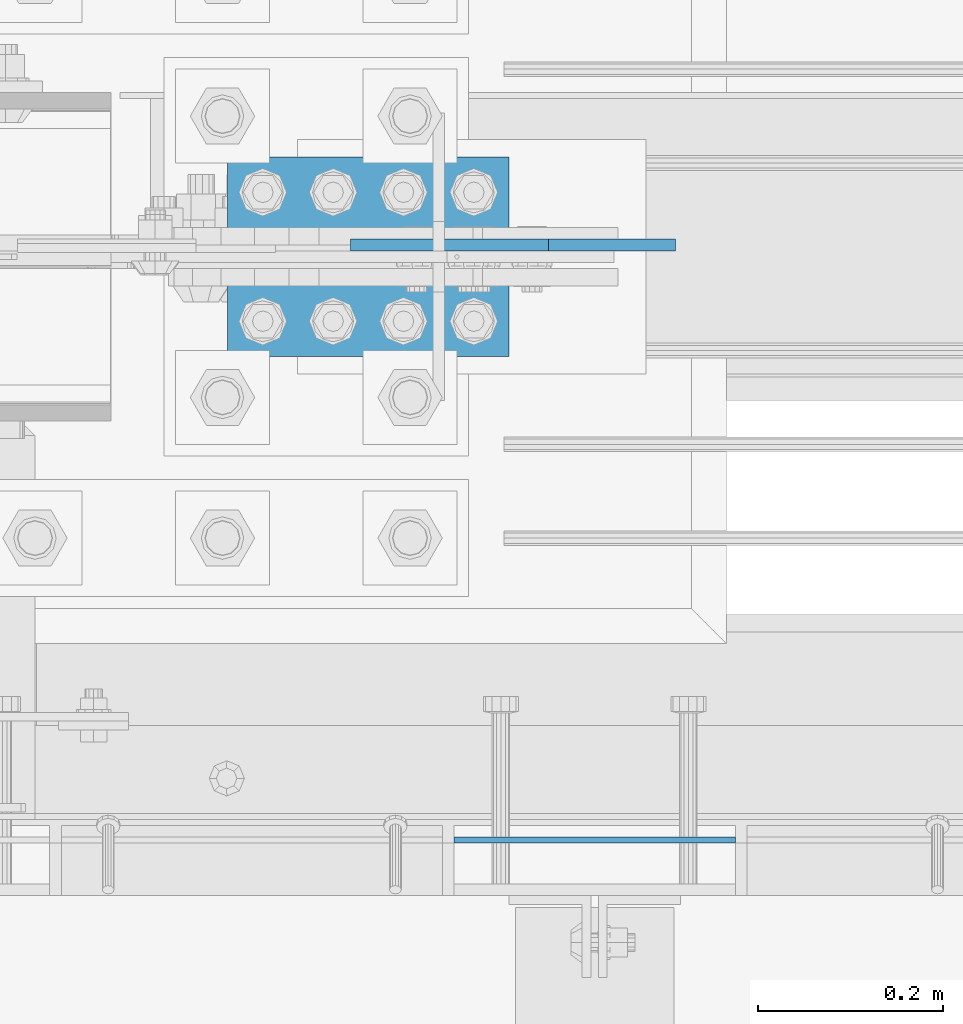
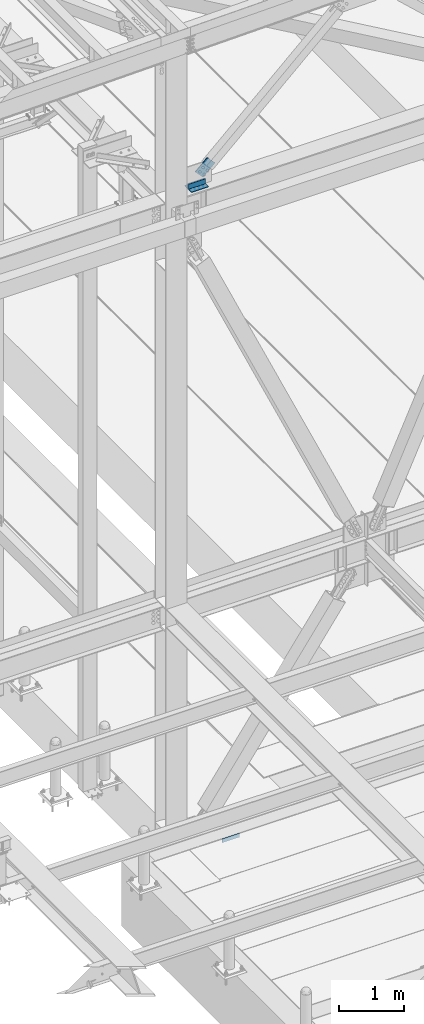
# One storey, part 2022 of 3843: 3 beams, 1 member, 4 elements without a shape of their own.
"""IFC2X3 building model written with IfcOpenShell, lengths in millimetres."""

from ifc_helpers import new_model, si_unit, frame, origin_with_axes, place, context, subcontext, project, spatial, faceted_brep, material, type_object, element, aggregate, save


model = new_model("IFC2X3")

# Units and contexts
model_context = context("Model", 3, precision=1e-05, world=origin_with_axes())
body_context = subcontext(model_context, "Body", "Model", "MODEL_VIEW")
ifc_project = project(units=[si_unit("LENGTHUNIT", "METRE", prefix="MILLI"), si_unit("AREAUNIT", "SQUARE_METRE"), si_unit("VOLUMEUNIT", "CUBIC_METRE"), si_unit("MASSUNIT", "GRAM", prefix="KILO"), si_unit("TIMEUNIT", "SECOND"), si_unit("PLANEANGLEUNIT", "RADIAN"), si_unit("SOLIDANGLEUNIT", "STERADIAN"), si_unit("THERMODYNAMICTEMPERATUREUNIT", "DEGREE_CELSIUS"), si_unit("LUMINOUSINTENSITYUNIT", "LUMEN")], contexts=[model_context])

# Site, building, storey
site_placement = place(None, origin_with_axes())
site = spatial("IfcSite", under=ifc_project, at=site_placement, CompositionType="ELEMENT")
building_placement = place(site_placement, origin_with_axes())
building = spatial("IfcBuilding", under=site, at=building_placement, Name="Undefined", CompositionType="ELEMENT")
storey_placement = place(building_placement, origin_with_axes())
storey = spatial("IfcBuildingStorey", under=building, at=storey_placement, Name="Undefined", CompositionType="ELEMENT", Elevation=0.0)

# Assembly, beam
assembly_1_placement = place(storey_placement, origin_with_axes())
assembly_1 = element("IfcElementAssembly", 1, at=assembly_1_placement, inside=storey, Name="EMBED PLATE", AssemblyPlace="NOTDEFINED", PredefinedType="RIGID_FRAME")
ifc_material_1 = material(Name="STEEL/A36")
beam_type_1 = type_object("IfcBeamType", PredefinedType="NOTDEFINED")
beam_1_placement = place(assembly_1_placement, frame((42618.025, 24984.0749969482, 30441.9), z_axis=(0.0, 0.0, 1.0), x_axis=(1.0, 0.0, 0.0)))
beam_1 = element("IfcBeam", 2, at=beam_1_placement, type_object=beam_type_1, material=ifc_material_1, Name="PLATE", context=body_context, shape_type="Brep", body=[
    faceted_brep([(0.0, 3.17500000000291, -38.0999999999985), (0.0, 3.17500000000291, 38.0999999999985), (304.800000000003, 3.17499999999927, 38.0999999999985), (304.800000000003, 3.17499999999927, -38.0999999999985), (0.0, -3.17500000000291, 38.0999999999985), (304.800000000003, -3.17499999999927, 38.0999999999985), (0.0, -3.17500000000291, -38.0999999999985), (304.800000000003, -3.17499999999927, -38.0999999999985)], [[[0, 1, 2, 3]], [[1, 4, 5, 2]], [[4, 6, 7, 5]], [[6, 0, 3, 7]], [[5, 7, 3, 2]], [[6, 4, 1, 0]]]),
])
aggregate(assembly_1, [beam_1])

assembly_2_placement = place(storey_placement, origin_with_axes())
assembly_2 = element("IfcElementAssembly", 3, at=assembly_2_placement, inside=storey, Name="ANGLE", AssemblyPlace="NOTDEFINED", PredefinedType="RIGID_FRAME")
ifc_material_2 = material(Name="STEEL/A572-50")
beam_type_2 = type_object("IfcBeamType", Name="L4X4X3/8", PredefinedType="NOTDEFINED")
beam_2_placement = place(assembly_2_placement, frame((42677.5562499993, 25673.0499999454, 42519.5999999992), z_axis=(0.0, 0.0, 1.0), x_axis=(-1.0, 0.0, 0.0)))
beam_2 = element("IfcBeam", 4, at=beam_2_placement, type_object=beam_type_2, material=ifc_material_2, Name="ANGLE", ObjectType="L4X4X3/8", context=body_context, shape_type="Brep", body=[
    faceted_brep([(0.0, 50.8000000000029, -50.8000000000029), (0.0, 50.8000000000029, 50.8000000000029), (304.800000000003, 50.8000000000029, 50.8000000000029), (304.800000000003, 50.8000000000029, -50.8000000000029), (0.0, 41.2750000000015, 50.8000000000029), (304.800000000003, 41.2749999999942, 50.8000000000029), (0.0, 41.2749999999942, -41.2750000000015), (304.800000000003, 41.2749999999942, -41.2750000000015), (0.0, -50.8000000000029, -41.2750000000015), (304.800000000003, -50.8000000000029, -41.2750000000015), (0.0, -50.8000000000029, -50.8000000000029), (304.800000000003, -50.8000000000029, -50.8000000000029)], [[[0, 1, 2, 3]], [[1, 4, 5, 2]], [[4, 6, 7, 5]], [[6, 8, 9, 7]], [[8, 10, 11, 9]], [[10, 0, 3, 11]], [[5, 7, 9, 11, 3, 2]], [[10, 8, 6, 4, 1, 0]]]),
])
aggregate(assembly_2, [beam_2])

assembly_3_placement = place(storey_placement, origin_with_axes())
assembly_3 = element("IfcElementAssembly", 5, at=assembly_3_placement, inside=storey, Name="ANGLE", AssemblyPlace="NOTDEFINED", PredefinedType="RIGID_FRAME")
beam_3_placement = place(assembly_3_placement, frame((42372.7562499993, 25558.7499999454, 42519.5999999992), z_axis=(0.0, 0.0, 1.0), x_axis=(1.0, 0.0, 0.0)))
beam_3 = element("IfcBeam", 6, at=beam_3_placement, type_object=beam_type_2, material=ifc_material_2, Name="ANGLE", ObjectType="L4X4X3/8", context=body_context, shape_type="Brep", body=[
    faceted_brep([(0.0, 50.8000000000029, -50.8000000000029), (0.0, 50.8000000000029, 50.8000000000029), (304.800000000003, 50.8000000000029, 50.8000000000029), (304.800000000003, 50.8000000000029, -50.8000000000029), (0.0, 41.2750000000015, 50.8000000000029), (304.800000000003, 41.2749999999942, 50.8000000000029), (0.0, 41.2749999999942, -41.2750000000015), (304.800000000003, 41.2749999999942, -41.2750000000015), (0.0, -50.8000000000029, -41.2750000000015), (304.800000000003, -50.8000000000029, -41.2750000000015), (0.0, -50.8000000000029, -50.8000000000029), (304.800000000003, -50.8000000000029, -50.8000000000029)], [[[0, 1, 2, 3]], [[1, 4, 5, 2]], [[4, 6, 7, 5]], [[6, 8, 9, 7]], [[8, 10, 11, 9]], [[10, 0, 3, 11]], [[5, 7, 9, 11, 3, 2]], [[10, 8, 6, 4, 1, 0]]]),
])
aggregate(assembly_3, [beam_3])

# Assembly, member
assembly_4_placement = place(storey_placement, origin_with_axes())
assembly_4 = element("IfcElementAssembly", 7, at=assembly_4_placement, inside=storey, AssemblyPlace="NOTDEFINED", PredefinedType="RIGID_FRAME")
member_type = type_object("IfcMemberType", PredefinedType="NOTDEFINED")
member_placement = place(assembly_4_placement, frame((42574.5921049626, 25628.5999999454, 42670.4339661352), z_axis=(-0.678515287903948, 0.0, 0.734586280896004), x_axis=(0.734586280896006, 0.0, 0.678515287903946)))
member = element("IfcMember", 8, at=member_placement, type_object=member_type, material=ifc_material_2, Name="PLATE", context=body_context, shape_type="Brep", body=[
    faceted_brep([(1.74622982740402e-10, 6.35000000000582, -101.600000000195), (-1.67347025126219e-10, 6.35000000000582, 101.600000000151), (292.1000000028, 6.35000000000582, 101.600000000661), (292.100000003156, 6.35000000000582, -101.599999999686), (-1.67347025126219e-10, -6.35000000000582, 101.600000000151), (292.1000000028, -6.35000000000582, 101.600000000661), (1.74622982740402e-10, -6.35000000000582, -101.600000000195), (292.100000003156, -6.35000000000582, -101.599999999686)], [[[0, 1, 2, 3]], [[1, 4, 5, 2]], [[4, 6, 7, 5]], [[6, 0, 3, 7]], [[5, 7, 3, 2]], [[6, 4, 1, 0]]]),
])
aggregate(assembly_4, [member])

save(model, "model.ifc")
